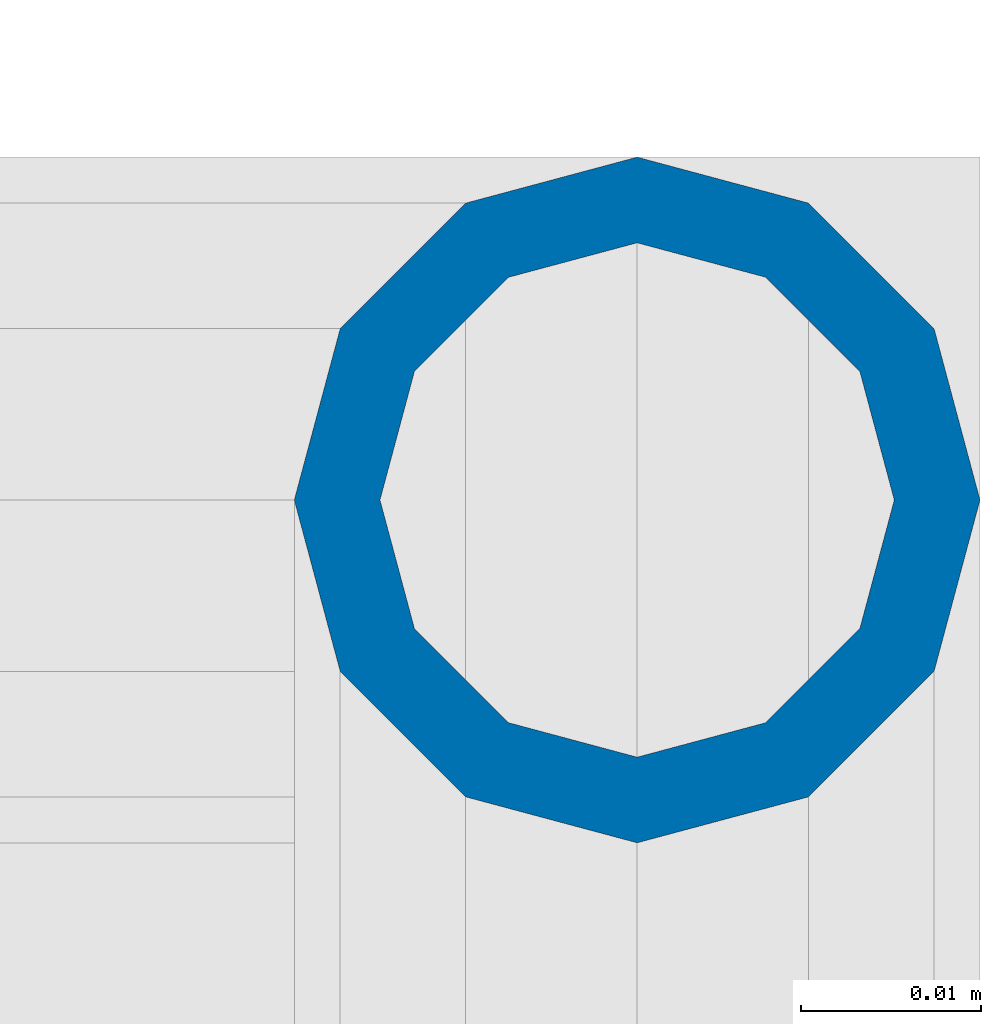
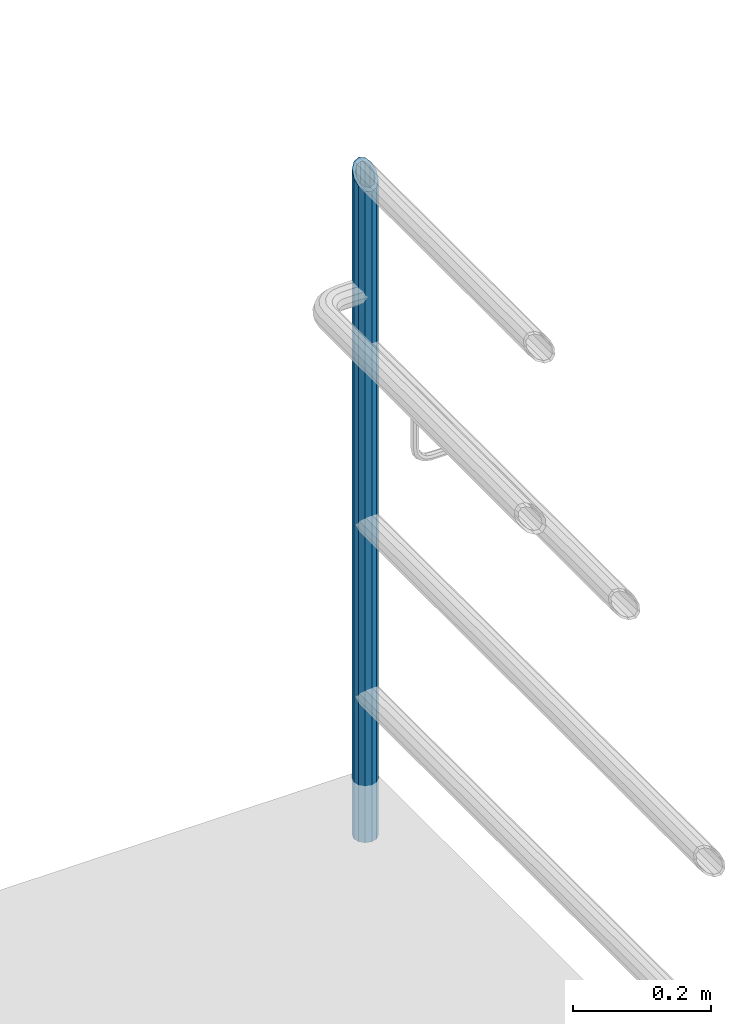
# One storey, part 675 of 1876: 1 column, 1 element without a shape of its own.
"""IFC2X3 building model written with IfcOpenShell, lengths in millimetres."""

import ifcopenshell
import ifcopenshell.guid

model = None  # the IFC model being written
_history = None  # IfcOwnerHistory: only IFC2X3 demands one
_inside = {}  # id of a spatial element -> (the spatial element, [elements in it])
_under = {}  # id of a project, library or spatial element -> (it, [spatial elements below it])
_declared = {}  # id of a project -> (the project, [libraries it declares])
_typed = {}  # id of a type object -> (the type object, [elements of that type])
_made_of = {}  # id of a material, layer set ... -> (it, [elements and type objects made of it])


def new_model(schema):
    """Start an empty IFC model of exactly this schema.

    Asked for "IFC4X3", IfcOpenShell would pick the latest addendum, in which some entities
    have other attributes; the version numbers below select the first issue.
    IFC2X3 requires an IfcOwnerHistory on every rooted entity: one is made here for all.
    """
    global model, _history
    if schema == "IFC4X3":
        model = ifcopenshell.file(schema_version=(4, 3, 0, 0))
    else:
        model = ifcopenshell.file(schema=schema)
    _inside.clear()
    _under.clear()
    _declared.clear()
    _typed.clear()
    _made_of.clear()
    _history = None
    if model.schema == "IFC2X3":
        org = make("IfcOrganization", Name="unknown")
        user = make(
            "IfcPersonAndOrganization",
            ThePerson=make("IfcPerson", FamilyName="unknown"),
            TheOrganization=org,
        )
        app = make(
            "IfcApplication",
            ApplicationDeveloper=org,
            Version="unknown",
            ApplicationFullName="unknown",
            ApplicationIdentifier="unknown",
        )
        _history = make(
            "IfcOwnerHistory",
            OwningUser=user,
            OwningApplication=app,
            ChangeAction="ADDED",
            CreationDate=0,
        )
    return model


def make(cls, **values):
    """One entity of the class cls with the attributes given. An attribute that is None is left unset."""
    return model.create_entity(
        cls, **{name: value for name, value in values.items() if value is not None}
    )


def rooted(cls, **values):
    """An entity with a GlobalId (a new one), such as an element, a storey or a relation."""
    return make(cls, GlobalId=ifcopenshell.guid.new(), OwnerHistory=_history, **values)


def si_unit(unit_type, name, prefix=None):
    """IfcSIUnit, for example si_unit("LENGTHUNIT", "METRE", prefix="MILLI")."""
    return make("IfcSIUnit", UnitType=unit_type, Prefix=prefix, Name=name)


def assignment(units):
    """IfcUnitAssignment: the units of a project."""
    return None if units is None else make("IfcUnitAssignment", Units=units)


def point(xyz):
    """IfcCartesianPoint."""
    return None if xyz is None else make("IfcCartesianPoint", Coordinates=xyz)


def direction(xyz):
    """IfcDirection."""
    return None if xyz is None else make("IfcDirection", DirectionRatios=xyz)


def frame(location, z_axis=None, x_axis=None):
    """IfcAxis2Placement3D, a coordinate frame: its origin and axes. An axis left out is left unset."""
    return make(
        "IfcAxis2Placement3D",
        Location=point(location),
        Axis=direction(z_axis),
        RefDirection=direction(x_axis),
    )


def origin_with_axes():
    """The frame at (0, 0, 0) with the z axis (0, 0, 1) and the x axis (1, 0, 0) written out."""
    return frame((0.0, 0.0, 0.0), z_axis=(0.0, 0.0, 1.0), x_axis=(1.0, 0.0, 0.0))


def place(relative_to, where):
    """IfcLocalPlacement: puts the frame where relative to a parent placement (None: the world)."""
    return make(
        "IfcLocalPlacement", PlacementRelTo=relative_to, RelativePlacement=where
    )


def context(
    kind, dimensions, precision=None, world=None, true_north=None, identifier=None
):
    """IfcGeometricRepresentationContext, for example the 3D "Model" context."""
    return make(
        "IfcGeometricRepresentationContext",
        ContextIdentifier=identifier,
        ContextType=kind,
        CoordinateSpaceDimension=dimensions,
        Precision=precision,
        WorldCoordinateSystem=world,
        TrueNorth=true_north,
    )


def subcontext(parent, identifier, kind, view, scale=None):
    """IfcGeometricRepresentationSubContext, for example "Body" below "Model"."""
    return make(
        "IfcGeometricRepresentationSubContext",
        ContextIdentifier=identifier,
        ContextType=kind,
        ParentContext=parent,
        TargetScale=scale,
        TargetView=view,
    )


def project(units=None, contexts=None):
    """IfcProject with its units and contexts."""
    return rooted(
        "IfcProject",
        Name="project",
        RepresentationContexts=contexts,
        UnitsInContext=assignment(units),
    )


def spatial(cls, under=None, at=None, **own):
    """A site, building, storey or space (cls), placed at a placement, below another one or the project."""
    s = rooted(cls, ObjectPlacement=at, **own)
    if under is not None:
        _under.setdefault(under.id(), (under, []))[1].append(s)
    return s


def faces_of(points, faces, orient=None, outer=None):
    """IfcFace entities. A face is a list of loops; a loop is a list of indices into points, from 0.

    orient and outer hold one flag for each loop. By default every Orientation is true, the
    first loop of a face is its IfcFaceOuterBound and the others are IfcFaceBound.
    """
    made = []
    for i, loops in enumerate(faces):
        bounds = []
        for j, loop in enumerate(loops):
            is_outer = j == 0 if outer is None else outer[i][j]
            bounds.append(
                make(
                    "IfcFaceOuterBound" if is_outer else "IfcFaceBound",
                    Bound=make("IfcPolyLoop", Polygon=[points[k] for k in loop]),
                    Orientation=True if orient is None else orient[i][j],
                )
            )
        made.append(make("IfcFace", Bounds=bounds))
    return made


def faceted_brep(points, faces, orient=None, outer=None, voids=None):
    """IfcFacetedBrep: a solid bounded by flat faces; with voids (closed shells), ...WithVoids."""
    shared = [point(p) for p in points]
    hull = make("IfcClosedShell", CfsFaces=faces_of(shared, faces, orient, outer))
    if voids is None:
        return make("IfcFacetedBrep", Outer=hull)
    return make(
        "IfcFacetedBrepWithVoids",
        Outer=hull,
        Voids=[
            make(cls, CfsFaces=faces_of(shared, fs, o, b)) for cls, fs, o, b in voids
        ],
    )


def shape(context_of_items, identifier, shape_type, items):
    """IfcShapeRepresentation: the items that make up one representation, for example the "Body"."""
    return make(
        "IfcShapeRepresentation",
        ContextOfItems=context_of_items,
        RepresentationIdentifier=identifier,
        RepresentationType=shape_type,
        Items=items,
    )


def material(Name=None, Category=None):
    """IfcMaterial."""
    return make("IfcMaterial", Name=Name, Category=Category)


def made_of(thing, what):
    """Note that an element or type object is made of a material, layer set ...; save() writes the relation."""
    if what is not None:
        _made_of.setdefault(what.id(), (what, []))[1].append(thing)
    return thing


def type_object(cls, material=None, **own):
    """A type object (cls), such as IfcWallType, which elements share."""
    return made_of(rooted(cls, **own), material)


def element(
    cls,
    number,
    at=None,
    inside=None,
    cuts=None,
    type_object=None,
    material=None,
    context=None,
    identifier="Body",
    shape_type=None,
    held_by="IfcProductDefinitionShape",
    body=None,
    shapes=None,
    **own,
):
    """One element of the class cls, such as IfcWall. Its Tag is "e" and its number.

    at: its placement. inside: the storey or other place that contains it. cuts: it is an
    opening in that element (IfcRelVoidsElement). A single representation is given by context,
    identifier, shape_type and body (its items); several are given by shapes. held_by: the class
    of the entity that holds the representations. save() writes the other relations.
    """
    e = rooted(cls, Tag="e%d" % number, ObjectPlacement=at, **own)
    if body is not None:
        shapes = [shape(context, identifier, shape_type, body)]
    if shapes is not None:
        e.Representation = make(held_by, Representations=shapes)
    if inside is not None:
        _inside.setdefault(inside.id(), (inside, []))[1].append(e)
    if cuts is not None:
        rooted(
            "IfcRelVoidsElement", RelatingBuildingElement=cuts, RelatedOpeningElement=e
        )
    if type_object is not None:
        _typed.setdefault(type_object.id(), (type_object, []))[1].append(e)
    return made_of(e, material)


def aggregate(whole, parts):
    """IfcRelAggregates: a whole, such as a stair, and the parts it consists of."""
    return rooted("IfcRelAggregates", RelatingObject=whole, RelatedObjects=parts)


def save(model, path):
    """Write the relations noted so far, then the file.

    IfcRelAggregates (storeys below a building ...), IfcRelContainedInSpatialStructure (elements
    in a storey), IfcRelDefinesByType, IfcRelAssociatesMaterial and IfcRelDeclares: one each for
    every whole, place, type object, material and project.
    """
    for whole, parts in _under.values():
        aggregate(whole, parts)
    for where, things in _inside.values():
        rooted(
            "IfcRelContainedInSpatialStructure",
            RelatedElements=things,
            RelatingStructure=where,
        )
    for kind, things in _typed.values():
        rooted("IfcRelDefinesByType", RelatedObjects=things, RelatingType=kind)
    for what, things in _made_of.values():
        rooted("IfcRelAssociatesMaterial", RelatedObjects=things, RelatingMaterial=what)
    for by, libraries in _declared.values():
        rooted("IfcRelDeclares", RelatingContext=by, RelatedDefinitions=libraries)
    model.write(path)


model = new_model("IFC2X3")

# Units and contexts
model_context = context("Model", 3, precision=1e-05, world=origin_with_axes())
body_context = subcontext(model_context, "Body", "Model", "MODEL_VIEW")
ifc_project = project(units=[si_unit("LENGTHUNIT", "METRE", prefix="MILLI"), si_unit("AREAUNIT", "SQUARE_METRE"), si_unit("VOLUMEUNIT", "CUBIC_METRE"), si_unit("MASSUNIT", "GRAM", prefix="KILO"), si_unit("TIMEUNIT", "SECOND"), si_unit("PLANEANGLEUNIT", "RADIAN"), si_unit("SOLIDANGLEUNIT", "STERADIAN"), si_unit("THERMODYNAMICTEMPERATUREUNIT", "DEGREE_CELSIUS"), si_unit("LUMINOUSINTENSITYUNIT", "LUMEN")], contexts=[model_context])

# Site, building, storey
site_placement = place(None, origin_with_axes())
site = spatial("IfcSite", under=ifc_project, at=site_placement, CompositionType="ELEMENT")
building_placement = place(site_placement, origin_with_axes())
building = spatial("IfcBuilding", under=site, at=building_placement, Name="Undefined", CompositionType="ELEMENT")
storey_placement = place(building_placement, origin_with_axes())
storey = spatial("IfcBuildingStorey", under=building, at=storey_placement, Name="Undefined", CompositionType="ELEMENT", Elevation=0.0)

# Assembly, column
assembly_placement = place(storey_placement, origin_with_axes())
assembly = element("IfcElementAssembly", 1, at=assembly_placement, inside=storey, Name="RAIL", AssemblyPlace="NOTDEFINED", PredefinedType="RIGID_FRAME")
ifc_material = material()
column_type = type_object("IfcColumnType", PredefinedType="NOTDEFINED")
column_placement = place(assembly_placement, frame((9556.7501953125, -2457.45, 76.2000030526367), z_axis=(0.0, 1.0, 0.0), x_axis=(0.0, 0.0, 1.0)))
column = element("IfcColumn", 2, at=column_placement, type_object=column_type, material=ifc_material, Name="POST", context=body_context, shape_type="Brep", body=[
    faceted_brep([(0.0, -14.2875000000004, 0.0), (0.0, -12.373337956571, 7.14375000000018), (1175.54375000408, -12.373337956571, 7.14375000000018), (1168.40000000408, -14.2875000000004, 0.0), (0.0, -7.14374999999927, 12.3733379565701), (1180.77333796065, -7.14374999999927, 12.3733379565701), (0.0, 0.0, 14.2874999999999), (1182.68750000408, 0.0, 14.2874999999999), (0.0, 7.14374999999927, 12.3733379565701), (1180.77333796065, 7.14374999999927, 12.3733379565701), (0.0, 12.373337956571, 7.14375000000018), (1175.54375000408, 12.373337956571, 7.14375000000018), (0.0, 14.2875000000004, 0.0), (1168.40000000408, 14.2875000000004, 0.0), (0.0, 12.373337956571, -7.14375000000018), (1161.25625000408, 12.373337956571, -7.14375000000018), (0.0, 7.14374999999927, -12.3733379565701), (1156.02666204751, 7.14374999999927, -12.3733379565701), (0.0, 0.0, -14.2874999999999), (1154.11250000408, 0.0, -14.2874999999999), (0.0, -7.14374999999927, -12.3733379565701), (1156.02666204751, -7.14374999999927, -12.3733379565701), (0.0, -12.373337956571, -7.14375000000018), (1161.25625000408, -12.373337956571, -7.14375000000018), (0.0, -19.0500000000002, 0.0), (0.0, -16.4977839420935, -9.52500000000146), (1158.87500000408, -16.4977839420935, -9.52500000000009), (1168.40000000408, -19.0499999999993, 0.0), (0.0, -9.52500000000009, -16.4977839420935), (1151.90221606199, -9.52499999999964, -16.4977839420935), (0.0, 0.0, -19.05), (1149.35000000408, 0.0, -19.0500000000002), (0.0, 9.52500000000009, -16.4977839420935), (1151.90221606199, 9.52499999999964, -16.4977839420935), (0.0, 16.4977839420935, -9.52500000000146), (1158.87500000408, 16.4977839420935, -9.52500000000009), (-9.09494701772928e-13, 19.05, -1.81898940354586e-12), (1168.40000000408, 19.0499999999993, 0.0), (0.0, 16.4977839420935, 9.52500000000146), (1177.92500000408, 16.4977839420935, 9.52500000000009), (0.0, 9.52500000000009, 16.4977839420935), (1184.89778394617, 9.52499999999964, 16.4977839420935), (0.0, 0.0, 19.0499999999993), (1187.45000000408, 0.0, 19.0500000000002), (0.0, -9.52500000000009, 16.4977839420935), (1184.89778394617, -9.52499999999964, 16.4977839420935), (0.0, -16.4977839420935, 9.52500000000146), (1177.92500000408, -16.4977839420935, 9.52500000000009)], [[[0, 1, 2, 3]], [[1, 4, 5, 2]], [[4, 6, 7, 5]], [[6, 8, 9, 7]], [[8, 10, 11, 9]], [[10, 12, 13, 11]], [[12, 14, 15, 13]], [[14, 16, 17, 15]], [[16, 18, 19, 17]], [[18, 20, 21, 19]], [[20, 22, 23, 21]], [[22, 0, 3, 23]], [[24, 25, 26, 27]], [[25, 28, 29, 26]], [[28, 30, 31, 29]], [[30, 32, 33, 31]], [[32, 34, 35, 33]], [[34, 36, 37, 35]], [[36, 38, 39, 37]], [[38, 40, 41, 39]], [[40, 42, 43, 41]], [[42, 44, 45, 43]], [[44, 46, 47, 45]], [[46, 24, 27, 47]], [[29, 31, 33, 35, 37, 39, 41, 43, 45, 47, 27, 26], [5, 7, 9, 11, 13, 15, 17, 19, 21, 23, 3, 2]], [[46, 44, 42, 40, 38, 36, 34, 32, 30, 28, 25, 24], [22, 20, 18, 16, 14, 12, 10, 8, 6, 4, 1, 0]]]),
])
aggregate(assembly, [column])

save(model, "model.ifc")
